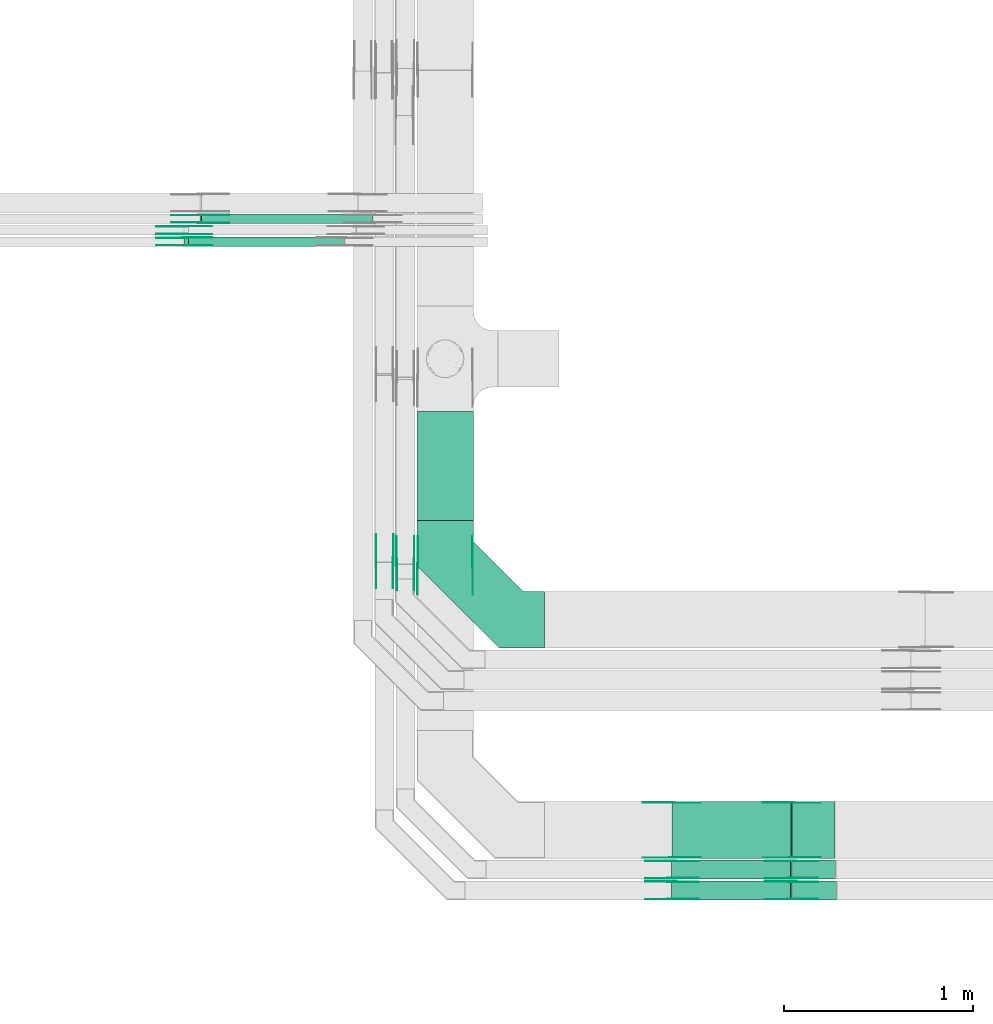
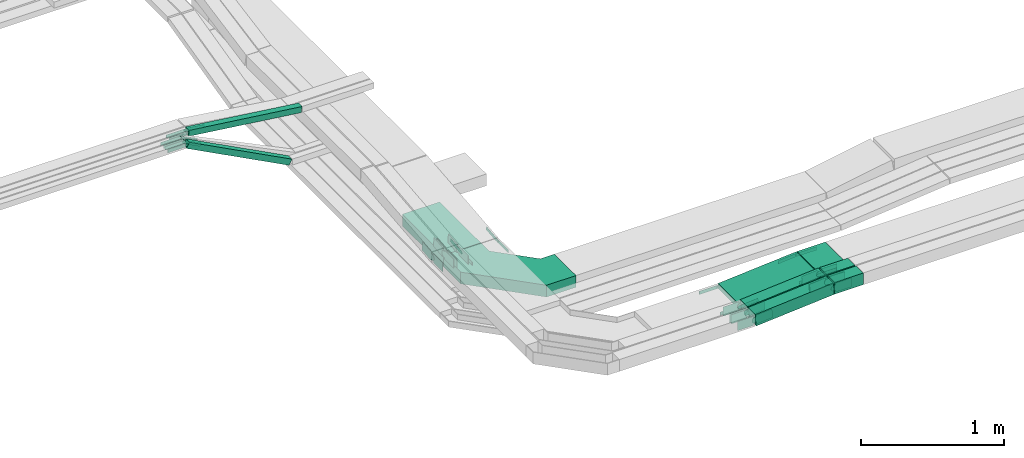
# One storey, part 6 of 33: 49 flow fittings, 9 flow segments.
"""IFC2X3 building model written with IfcOpenShell, lengths in millimetres."""

from ifc_helpers import new_model, entity, si_unit, converted_unit, derived_unit, direction, frame, frame_2d, origin, origin_2d_with_axis, place, context, subcontext, project, spatial, polyline, circle_curve, parameter, trimmed, segment, composite_curve, rectangle, outline, extrude, source, transform, mapped, material, type_object, type_shapes, element, save


model = new_model("IFC2X3")

# Units and contexts
model_context = context("Model", 3, precision=0.01, world=origin(), true_north=direction((6.12303176911189e-17, 1.0)))
body_context = subcontext(model_context, "Body", "Model", "MODEL_VIEW")
ifc_project = project(units=[si_unit("LENGTHUNIT", "METRE", prefix="MILLI"), si_unit("AREAUNIT", "SQUARE_METRE"), si_unit("VOLUMEUNIT", "CUBIC_METRE"), converted_unit("PLANEANGLEUNIT", "DEGREE", entity("IfcRatioMeasure", 0.0174532925199433), si_unit("PLANEANGLEUNIT", "RADIAN"), dimensions=[0, 0, 0, 0, 0, 0, 0]), si_unit("MASSUNIT", "GRAM", prefix="KILO"), derived_unit("MASSDENSITYUNIT", [(si_unit("MASSUNIT", "GRAM", prefix="KILO"), 1), (si_unit("LENGTHUNIT", "METRE"), -3)]), derived_unit("MOMENTOFINERTIAUNIT", [(si_unit("LENGTHUNIT", "METRE"), 4)]), si_unit("TIMEUNIT", "SECOND"), si_unit("FREQUENCYUNIT", "HERTZ"), si_unit("THERMODYNAMICTEMPERATUREUNIT", "DEGREE_CELSIUS"), derived_unit("THERMALTRANSMITTANCEUNIT", [(si_unit("MASSUNIT", "GRAM", prefix="KILO"), 1), (si_unit("THERMODYNAMICTEMPERATUREUNIT", "KELVIN"), -1), (si_unit("TIMEUNIT", "SECOND"), -3)]), derived_unit("VOLUMETRICFLOWRATEUNIT", [(si_unit("LENGTHUNIT", "METRE"), 3), (si_unit("TIMEUNIT", "SECOND"), -1)]), derived_unit("MASSFLOWRATEUNIT", [(si_unit("MASSUNIT", "GRAM", prefix="KILO"), 1), (si_unit("TIMEUNIT", "SECOND"), -1)]), derived_unit("ROTATIONALFREQUENCYUNIT", [(si_unit("TIMEUNIT", "SECOND"), -1)]), si_unit("ELECTRICCURRENTUNIT", "AMPERE"), si_unit("ELECTRICVOLTAGEUNIT", "VOLT"), si_unit("POWERUNIT", "WATT"), si_unit("FORCEUNIT", "NEWTON", prefix="KILO"), si_unit("ILLUMINANCEUNIT", "LUX"), si_unit("LUMINOUSFLUXUNIT", "LUMEN"), si_unit("LUMINOUSINTENSITYUNIT", "CANDELA"), derived_unit("USERDEFINED", [(si_unit("MASSUNIT", "GRAM", prefix="KILO"), -1), (si_unit("LENGTHUNIT", "METRE"), -2), (si_unit("TIMEUNIT", "SECOND"), 3), (si_unit("LUMINOUSFLUXUNIT", "LUMEN"), 1)]), derived_unit("LINEARVELOCITYUNIT", [(si_unit("LENGTHUNIT", "METRE"), 1), (si_unit("TIMEUNIT", "SECOND"), -1)]), si_unit("PRESSUREUNIT", "PASCAL"), derived_unit("USERDEFINED", [(si_unit("LENGTHUNIT", "METRE"), -2), (si_unit("MASSUNIT", "GRAM", prefix="KILO"), 1), (si_unit("TIMEUNIT", "SECOND"), -2)]), derived_unit("LINEARFORCEUNIT", [(si_unit("MASSUNIT", "GRAM", prefix="KILO"), 1), (si_unit("LENGTHUNIT", "METRE"), 1), (si_unit("TIMEUNIT", "SECOND"), -2), (si_unit("LENGTHUNIT", "METRE"), -1)]), derived_unit("PLANARFORCEUNIT", [(si_unit("MASSUNIT", "GRAM", prefix="KILO"), 1), (si_unit("LENGTHUNIT", "METRE"), 1), (si_unit("TIMEUNIT", "SECOND"), -2), (si_unit("LENGTHUNIT", "METRE"), -2)])], contexts=[model_context])

# Site, building, storey
site_placement = place(None, frame((0.0, -0.00077364408347762, 0.0)))
site = spatial("IfcSite", under=ifc_project, at=site_placement, CompositionType="ELEMENT")
building_placement = place(site_placement, origin())
building = spatial("IfcBuilding", under=site, at=building_placement, CompositionType="ELEMENT")
storey_placement = place(building_placement, frame((0.0, 0.0, 8100.0)))
storey = spatial("IfcBuildingStorey", under=building, at=storey_placement, CompositionType="ELEMENT", Elevation=8100.0)

# Flow segments
cable_carrier_segment_type = type_object("IfcCableCarrierSegmentType", PredefinedType="CABLETRAYSEGMENT")
flow_segment_1_placement = place(storey_placement, frame((18246.0523642072, 10520.9985534668, 2500.0)))
element("IfcFlowSegment", 1, at=flow_segment_1_placement, inside=storey, type_object=cable_carrier_segment_type, context=body_context, shape_type="SweptSolid", body=[
    extrude(rectangle(XDim=575.248008213486, YDim=300.000000000001, at=frame_2d((0.0, 2.17426077142591e-12), x_axis=(1.0, 0.0))), frame((150.0, 287.624004106748, 0.0), z_axis=(0.0, 0.0, 1.0), x_axis=(0.0, -1.0, 0.0)), (0.0, 0.0, 1.0), 99.9999999999989),
])
flow_segment_2_placement = place(storey_placement, frame((19596.2234512399, 8732.04668110773, 2740.2604319389)))
element("IfcFlowSegment", 2, at=flow_segment_2_placement, inside=storey, type_object=cable_carrier_segment_type, context=body_context, shape_type="SweptSolid", body=[
    extrude(rectangle(XDim=50.0000000000006, YDim=299.999999999999, at=frame_2d((0.0, 0.0), x_axis=(0.0, 1.0))), frame((1.96240772478632, 150.0, 24.922860107173), z_axis=(0.996914404286907, 0.0, 0.0784963089914518), x_axis=(0.0, 1.0, 0.0)), (0.0, 0.0, 1.0), 632.69257167876),
])
flow_segment_3_placement = place(storey_placement, frame((19595.2357822246, 8622.45182054443, 2739.93772748351)))
element("IfcFlowSegment", 3, at=flow_segment_3_placement, inside=storey, type_object=cable_carrier_segment_type, context=body_context, shape_type="SweptSolid", body=[
    extrude(rectangle(XDim=99.9999999999994, YDim=100.000000000001, at=frame_2d((0.0, 0.0), x_axis=(0.0, 1.0))), frame((3.93517206503428, 50.0, 49.8449036594347), z_axis=(0.996898073188744, 0.0, 0.0787034413006861), x_axis=(0.0, 1.0, 0.0)), (0.0, 0.0, 1.0), 630.726472303646),
])
flow_segment_4_placement = place(storey_placement, frame((19595.2938542408, 8512.45182054444, 2739.72291755436)))
element("IfcFlowSegment", 4, at=flow_segment_4_placement, inside=storey, type_object=cable_carrier_segment_type, context=body_context, shape_type="SweptSolid", body=[
    extrude(rectangle(XDim=99.9999999999991, YDim=99.9999999999989, at=frame_2d((0.0, 0.0), x_axis=(0.0, 1.0))), frame((3.92481544955964, 50.0, 49.8457202143459), z_axis=(0.996914404286927, 0.0, 0.0784963089911935), x_axis=(0.0, 1.0, 0.0)), (0.0, 0.0, 1.0), 630.673844252395),
])
flow_segment_5_placement = place(storey_placement, frame((20233.1995045216, 8732.04668110774, 2790.01530223377)))
element("IfcFlowSegment", 5, at=flow_segment_5_placement, inside=storey, type_object=cable_carrier_segment_type, context=body_context, shape_type="SweptSolid", body=[
    extrude(rectangle(XDim=226.881978270854, YDim=299.999999999999, at=frame_2d((0.0, 5.40012479177676e-13), x_axis=(1.0, 0.0))), frame((113.440989135427, 150.0, 0.0), z_axis=(0.0, 0.0, 1.0), x_axis=(-1.0, 0.0, 0.0)), (0.0, 0.0, 1.0), 50.0000000000016),
])
flow_segment_6_placement = place(storey_placement, frame((20234.1878431417, 8622.45182054443, 2789.6691825218)))
element("IfcFlowSegment", 6, at=flow_segment_6_placement, inside=storey, type_object=cable_carrier_segment_type, context=body_context, shape_type="SweptSolid", body=[
    extrude(rectangle(XDim=228.057615509405, YDim=99.9999999999989, at=origin_2d_with_axis()), frame((114.028807754702, 50.0, 0.0), z_axis=(0.0, 0.0, 1.0), x_axis=(-1.0, 0.0, 0.0)), (0.0, 0.0, 1.0), 99.9999999999989),
])
flow_segment_7_placement = place(storey_placement, frame((20234.1822245224, 8512.45182054444, 2789.31932519733)))
element("IfcFlowSegment", 7, at=flow_segment_7_placement, inside=storey, type_object=cable_carrier_segment_type, context=body_context, shape_type="SweptSolid", body=[
    extrude(rectangle(XDim=232.215307012604, YDim=99.9999999999989, at=origin_2d_with_axis()), frame((116.107653506302, 50.0, 0.0), z_axis=(0.0, 0.0, 1.0), x_axis=(-1.0, 0.0, 0.0)), (0.0, 0.0, 1.0), 99.9999999999989),
])
flow_segment_8_placement = place(storey_placement, frame((17015.1894000044, 11971.7526237039, 2626.62910408954)))
element("IfcFlowSegment", 8, at=flow_segment_8_placement, inside=storey, type_object=cable_carrier_segment_type, context=body_context, shape_type="SweptSolid", body=[
    extrude(rectangle(XDim=49.9999999999963, YDim=50.0000000000016, at=frame_2d((0.0, 0.0), x_axis=(0.0, 1.0))), frame((11.6001748667633, 25.0, 454.59600343892), z_axis=(0.885831535280106, 0.0, -0.464006994670651), x_axis=(0.0, 1.0, 0.0)), (0.0, 0.0, 1.0), 931.990724329228),
])
flow_segment_9_placement = place(storey_placement, frame((17099.2422570055, 12091.7526237039, 2944.30381418259)))
element("IfcFlowSegment", 9, at=flow_segment_9_placement, inside=storey, type_object=cable_carrier_segment_type, context=body_context, shape_type="SweptSolid", body=[
    extrude(rectangle(XDim=50.0000000000024, YDim=50.0000000000016, at=origin_2d_with_axis()), frame((3.15561380538458, 25.0, 140.338010413386), z_axis=(0.992001694765703, 0.0, -0.126224552215377), x_axis=(0.126224552215377, 0.0, 0.992001694765703)), (0.0, 0.0, 1.0), 915.336723453825),
])

# Flow fittings
ifc_material_1 = material()
cable_carrier_fitting_type_1 = type_object("IfcCableCarrierFittingType", Name="470_DKC_G5_Sheet horizontal bend:-", PredefinedType="NOTDEFINED", material=ifc_material_1)
shared_shape_1 = source(origin(), body_context, "Body", "SweptSolid", [
    extrude(outline(polyline([(-307.0, -369.0), (-68.8679656440352, -369.0), (369.0, 68.8679656440351), (369.0, 307.0), (69.0, 307.0), (69.0, 193.132034355964), (-193.132034355963, -69.0), (-307.0, -69.0), (-307.0, -369.0)])), frame((-219.0, 219.0, -50.0)), (0.0, 0.0, 1.0), 100.0),
])
type_shapes(cable_carrier_fitting_type_1, [shared_shape_1])
flow_fitting_placement = place(storey_placement, frame((18396.0523642072, 9994.99855346684, 2550.0), z_axis=(0.0, 0.0, 1.0), x_axis=(0.0, -1.0, 0.0)))
element("IfcFlowFitting", 10, at=flow_fitting_placement, inside=storey, type_object=cable_carrier_fitting_type_1, material=ifc_material_1, Name="470_DKC_G5_Sheet horizontal bend:-", ObjectType="470_DKC_G5_Sheet horizontal bend:-", context=body_context, shape_type="MappedRepresentation", body=[
    mapped(shared_shape_1, transform((0.0, 0.0, 0.0), scale=1.0)),
])
ifc_material_2 = material(Name="G")
cable_carrier_fitting_type_2 = type_object("IfcCableCarrierFittingType", PredefinedType="NOTDEFINED", material=ifc_material_2)
shared_shape_2 = source(origin(), body_context, "Body", "SweptSolid", [
    extrude(outline(composite_curve([segment(trimmed(circle_curve(frame_2d((-44.5901162790698, 0.0), x_axis=(1.0, 0.0)), 12.5), [parameter(90.0000000000007)], [parameter(270.0)], True, "PARAMETER"), True, "CONTINUOUS"), segment(polyline([(-44.5901162790697, -12.5), (-33.0901162790698, -12.5)]), True, "CONTINUOUS"), segment(polyline([(-33.0901162790698, -12.5), (-31.2296511627907, -14.5)]), True, "CONTINUOUS"), segment(polyline([(-31.2296511627907, -14.5), (108.90988372093, -14.5)]), True, "CONTINUOUS"), segment(polyline([(108.90988372093, -14.5), (108.90988372093, 14.5)]), True, "CONTINUOUS"), segment(polyline([(108.90988372093, 14.5), (-31.2296511627907, 14.5)]), True, "CONTINUOUS"), segment(polyline([(-31.2296511627907, 14.5), (-33.0901162790698, 12.5)]), True, "CONTINUOUS"), segment(polyline([(-33.0901162790698, 12.5), (-44.5901162790699, 12.5)]), True, "CONTINUOUS")], self_intersect=False)), frame((44.5901162790698, 0.0, 0.0), z_axis=(0.0, 0.0, -1.0), x_axis=(1.0, 0.0, 0.0)), (0.0, 0.0, -1.0), 2.0),
])
type_shapes(cable_carrier_fitting_type_2, [shared_shape_2])
for number, where, z_axis, x_axis in (
    (11, (20231.0595493208, 8736.58668109758, 2815.01530223381), (0.0, -1.0, 0.0), (-0.996914404286911, 0.0, -0.0784963089914033)),
    (12, (18250.5923641973, 10282.0466811094, 2765.0153134614), (-1.0, 0.0, 0.0), (0.0, -1.0, 0.0)),
    (13, (17099.5829619713, 12137.2126237141, 3085.0), (0.0, 1.0, 0.0), (0.992001694765699, 0.0, -0.126224552215409)),
    (14, (17019.5829619709, 12017.2126237141, 3085.0), (0.0, 1.0, 0.0), (0.885831535280083, 0.0, -0.464006994670695)),
    (15, (17019.582961971, 12077.2126237141, 3085.0), (0.0, 1.0, 0.0), (0.898384360919165, 0.0, -0.439210132005016)),
    (16, (19596.0525068004, 9027.50668111789, 2765.01531346139), (0.0, 1.0, 0.0), (-1.0, 0.0, 0.0)),
):
    element("IfcFlowFitting", number, at=place(storey_placement, frame(where, z_axis=z_axis, x_axis=x_axis)), inside=storey, type_object=cable_carrier_fitting_type_2, material=ifc_material_2, context=body_context, shape_type="MappedRepresentation", body=[
        mapped(shared_shape_2, transform((0.0, 0.0, 0.0), scale=1.0)),
    ])
cable_carrier_fitting_type_3 = type_object("IfcCableCarrierFittingType", PredefinedType="NOTDEFINED", material=ifc_material_2)
shared_shape_3 = source(origin(), body_context, "Body", "SweptSolid", [
    extrude(outline(composite_curve([segment(trimmed(circle_curve(frame_2d((-44.5901162790697, 0.0), x_axis=(1.0, 0.0)), 12.5), [parameter(90.0000000000007)], [parameter(270.0)], True, "PARAMETER"), True, "CONTINUOUS"), segment(polyline([(-44.5901162790697, -12.5), (-33.0901162790697, -12.5)]), True, "CONTINUOUS"), segment(polyline([(-33.0901162790697, -12.5), (-31.2296511627907, -14.5)]), True, "CONTINUOUS"), segment(polyline([(-31.2296511627907, -14.5), (108.90988372093, -14.5)]), True, "CONTINUOUS"), segment(polyline([(108.90988372093, -14.5), (108.90988372093, 14.5)]), True, "CONTINUOUS"), segment(polyline([(108.90988372093, 14.5), (-31.2296511627907, 14.5)]), True, "CONTINUOUS"), segment(polyline([(-31.2296511627907, 14.5), (-33.0901162790698, 12.5)]), True, "CONTINUOUS"), segment(polyline([(-33.0901162790698, 12.5), (-44.5901162790699, 12.5)]), True, "CONTINUOUS")], self_intersect=False)), frame((44.5901162790697, 0.0, 0.0)), (0.0, 0.0, 1.0), 2.0),
])
type_shapes(cable_carrier_fitting_type_3, [shared_shape_3])
for number, where, z_axis, x_axis in (
    (17, (20231.0595493208, 9027.5066811179, 2815.01530223381), (0.0, 1.0, 0.0), (-0.996914404286911, 0.0, -0.0784963089914033)),
    (18, (18541.5123642176, 10282.0466811094, 2765.0153134614), (1.0, 0.0, 0.0), (0.0, -1.0, 0.0)),
    (19, (17099.5829619713, 12096.2926236938, 3085.0), (0.0, -1.0, 0.0), (0.992001694765699, 0.0, -0.126224552215409)),
    (20, (17019.5829619709, 11976.2926236938, 3085.0), (0.0, -1.0, 0.0), (0.885831535280083, 0.0, -0.464006994670695)),
    (21, (17019.582961971, 12036.2926236938, 3085.0), (0.0, -1.0, 0.0), (0.898384360919165, 0.0, -0.439210132005016)),
    (22, (19596.0525068004, 8736.58668109757, 2765.01531346139), (0.0, -1.0, 0.0), (-1.0, 0.0, 0.0)),
):
    element("IfcFlowFitting", number, at=place(storey_placement, frame(where, z_axis=z_axis, x_axis=x_axis)), inside=storey, type_object=cable_carrier_fitting_type_3, material=ifc_material_2, context=body_context, shape_type="MappedRepresentation", body=[
        mapped(shared_shape_3, transform((0.0, 0.0, 0.0), scale=1.0)),
    ])
cable_carrier_fitting_type_4 = type_object("IfcCableCarrierFittingType", PredefinedType="NOTDEFINED", material=ifc_material_2)
shared_shape_4 = source(origin(), body_context, "Body", "SweptSolid", [
    extrude(outline(composite_curve([segment(trimmed(circle_curve(frame_2d((-44.5901162790698, 0.0), x_axis=(1.0, 0.0)), 12.5), [parameter(90.0000000000007)], [parameter(270.0)], True, "PARAMETER"), True, "CONTINUOUS"), segment(polyline([(-44.5901162790697, -12.5), (-33.0901162790698, -12.5)]), True, "CONTINUOUS"), segment(polyline([(-33.0901162790698, -12.5), (-31.2296511627907, -14.5)]), True, "CONTINUOUS"), segment(polyline([(-31.2296511627907, -14.5), (108.90988372093, -14.5)]), True, "CONTINUOUS"), segment(polyline([(108.90988372093, -14.5), (108.90988372093, 14.5)]), True, "CONTINUOUS"), segment(polyline([(108.90988372093, 14.5), (-31.2296511627907, 14.5)]), True, "CONTINUOUS"), segment(polyline([(-31.2296511627907, 14.5), (-33.0901162790698, 12.5)]), True, "CONTINUOUS"), segment(polyline([(-33.0901162790698, 12.5), (-44.5901162790699, 12.5)]), True, "CONTINUOUS")], self_intersect=False)), frame((44.5901162790698, 0.0, 0.0), z_axis=(0.0, 0.0, -1.0), x_axis=(1.0, 0.0, 0.0)), (0.0, 0.0, -1.0), 2.0),
])
type_shapes(cable_carrier_fitting_type_4, [shared_shape_4])
for number, where, z_axis, x_axis in (
    (23, (20231.0595493207, 9025.5066811179, 2815.01530223381), (0.0, 1.0, 0.0), (1.0, 0.0, 0.0)),
    (24, (18539.5123642176, 10282.0466811094, 2765.0153134614), (1.0, 0.0, 0.0), (0.0, 0.99497485470274, 0.100125114278398)),
    (25, (17099.5829619713, 12098.2926236938, 3085.0), (0.0, -1.0, 0.0), (-1.0, 0.0, 0.0)),
    (26, (17019.5829619709, 11978.2926236938, 3085.0), (0.0, -1.0, 0.0), (-1.0, 0.0, 0.0)),
    (27, (17019.582961971, 12038.2926236938, 3085.0), (0.0, -1.0, 0.0), (-1.0, 0.0, 0.0)),
    (28, (19596.0525068004, 8738.58668109757, 2765.01531346139), (0.0, -1.0, 0.0), (0.996914404286914, 0.0, 0.0784963089913655)),
):
    element("IfcFlowFitting", number, at=place(storey_placement, frame(where, z_axis=z_axis, x_axis=x_axis)), inside=storey, type_object=cable_carrier_fitting_type_4, material=ifc_material_2, context=body_context, shape_type="MappedRepresentation", body=[
        mapped(shared_shape_4, transform((0.0, 0.0, 0.0), scale=1.0)),
    ])
cable_carrier_fitting_type_5 = type_object("IfcCableCarrierFittingType", PredefinedType="NOTDEFINED", material=ifc_material_2)
shared_shape_5 = source(origin(), body_context, "Body", "SweptSolid", [
    extrude(outline(composite_curve([segment(trimmed(circle_curve(frame_2d((-44.5901162790697, 0.0), x_axis=(1.0, 0.0)), 12.5), [parameter(90.0000000000007)], [parameter(270.0)], True, "PARAMETER"), True, "CONTINUOUS"), segment(polyline([(-44.5901162790697, -12.5), (-33.0901162790697, -12.5)]), True, "CONTINUOUS"), segment(polyline([(-33.0901162790697, -12.5), (-31.2296511627907, -14.5)]), True, "CONTINUOUS"), segment(polyline([(-31.2296511627907, -14.5), (108.90988372093, -14.5)]), True, "CONTINUOUS"), segment(polyline([(108.90988372093, -14.5), (108.90988372093, 14.5)]), True, "CONTINUOUS"), segment(polyline([(108.90988372093, 14.5), (-31.2296511627907, 14.5)]), True, "CONTINUOUS"), segment(polyline([(-31.2296511627907, 14.5), (-33.0901162790698, 12.5)]), True, "CONTINUOUS"), segment(polyline([(-33.0901162790698, 12.5), (-44.5901162790699, 12.5)]), True, "CONTINUOUS")], self_intersect=False)), frame((44.5901162790697, 0.0, 0.0)), (0.0, 0.0, 1.0), 2.0),
])
type_shapes(cable_carrier_fitting_type_5, [shared_shape_5])
for number, where, z_axis, x_axis in (
    (29, (20231.0595493207, 8738.58668109759, 2815.01530223381), (0.0, -1.0, 0.0), (1.0, 0.0, 0.0)),
    (30, (18252.5923641973, 10282.0466811094, 2765.0153134614), (-1.0, 0.0, 0.0), (0.0, 0.99497485470274, 0.100125114278398)),
    (31, (17099.5829619713, 12135.2126237141, 3085.0), (0.0, 1.0, 0.0), (-1.0, 0.0, 0.0)),
    (32, (17019.5829619709, 12015.2126237141, 3085.0), (0.0, 1.0, 0.0), (-1.0, 0.0, 0.0)),
    (33, (17019.582961971, 12075.2126237141, 3085.0), (0.0, 1.0, 0.0), (-1.0, 0.0, 0.0)),
    (34, (19596.0525068004, 9025.50668111788, 2765.01531346139), (0.0, 1.0, 0.0), (0.996914404286914, 0.0, 0.0784963089913655)),
):
    element("IfcFlowFitting", number, at=place(storey_placement, frame(where, z_axis=z_axis, x_axis=x_axis)), inside=storey, type_object=cable_carrier_fitting_type_5, material=ifc_material_2, context=body_context, shape_type="MappedRepresentation", body=[
        mapped(shared_shape_5, transform((0.0, 0.0, 0.0), scale=1.0)),
    ])
cable_carrier_fitting_type_6 = type_object("IfcCableCarrierFittingType", PredefinedType="NOTDEFINED", material=ifc_material_2)
shared_shape_6 = source(origin(), body_context, "Body", "SweptSolid", [
    extrude(outline(composite_curve([segment(trimmed(circle_curve(frame_2d((-41.4651162790697, 0.0), x_axis=(1.0, 0.0)), 25.0), [parameter(90.0000000000007)], [parameter(270.0)], True, "PARAMETER"), True, "CONTINUOUS"), segment(polyline([(-41.4651162790697, -25.0), (-29.9651162790697, -25.0)]), True, "CONTINUOUS"), segment(polyline([(-29.9651162790697, -25.0), (-28.1046511627907, -38.5)]), True, "CONTINUOUS"), segment(polyline([(-28.1046511627907, -38.5), (99.5348837209303, -38.5)]), True, "CONTINUOUS"), segment(polyline([(99.5348837209303, -38.5), (99.5348837209303, 38.5)]), True, "CONTINUOUS"), segment(polyline([(99.5348837209303, 38.5), (-28.1046511627907, 38.5)]), True, "CONTINUOUS"), segment(polyline([(-28.1046511627907, 38.5), (-29.9651162790697, 25.0)]), True, "CONTINUOUS"), segment(polyline([(-29.9651162790697, 25.0), (-41.46511627907, 25.0)]), True, "CONTINUOUS")], self_intersect=False)), frame((41.4651162790697, 0.0, 0.0), z_axis=(0.0, 0.0, -1.0), x_axis=(1.0, 0.0, 0.0)), (0.0, 0.0, -1.0), 2.0),
])
type_shapes(cable_carrier_fitting_type_6, [shared_shape_6])
for number, where, z_axis, x_axis in (
    (35, (18231.5123642175, 10292.4518205444, 2789.53642365382), (1.0, 0.0, 0.0), (0.0, 0.994821450765371, 0.101637990422292)),
    (36, (18121.5123642176, 10302.4518205449, 2789.32351929117), (1.0, 0.0, 0.0), (0.0, 0.994903033239732, 0.100836275468608)),
    (37, (20231.0595493208, 8626.99182053427, 2839.66918252182), (0.0, -1.0, 0.0), (-0.99689807318874, 0.0, -0.0787034413007328)),
    (38, (20231.0595493209, 8516.99182053428, 2839.31932519734), (0.0, -1.0, 0.0), (-0.996914404286923, 0.0, -0.0784963089912431)),
    (39, (19596.105629802, 8607.91182055459, 2789.32351929118), (0.0, 1.0, 0.0), (-1.0, 0.0, 0.0)),
    (40, (19596.0523642071, 8717.91182055459, 2789.53642365381), (0.0, 1.0, 0.0), (-1.0, 0.0, 0.0)),
):
    element("IfcFlowFitting", number, at=place(storey_placement, frame(where, z_axis=z_axis, x_axis=x_axis)), inside=storey, type_object=cable_carrier_fitting_type_6, material=ifc_material_2, context=body_context, shape_type="MappedRepresentation", body=[
        mapped(shared_shape_6, transform((0.0, 0.0, 0.0), scale=1.0)),
    ])
cable_carrier_fitting_type_7 = type_object("IfcCableCarrierFittingType", PredefinedType="NOTDEFINED", material=ifc_material_2)
shared_shape_7 = source(origin(), body_context, "Body", "SweptSolid", [
    extrude(outline(composite_curve([segment(trimmed(circle_curve(frame_2d((-41.4651162790697, 0.0), x_axis=(1.0, 0.0)), 25.0), [parameter(90.0000000000007)], [parameter(270.0)], True, "PARAMETER"), True, "CONTINUOUS"), segment(polyline([(-41.4651162790697, -25.0), (-29.9651162790697, -25.0)]), True, "CONTINUOUS"), segment(polyline([(-29.9651162790697, -25.0), (-28.1046511627907, -38.5)]), True, "CONTINUOUS"), segment(polyline([(-28.1046511627907, -38.5), (99.5348837209303, -38.5)]), True, "CONTINUOUS"), segment(polyline([(99.5348837209303, -38.5), (99.5348837209303, 38.5)]), True, "CONTINUOUS"), segment(polyline([(99.5348837209303, 38.5), (-28.1046511627907, 38.5)]), True, "CONTINUOUS"), segment(polyline([(-28.1046511627907, 38.5), (-29.9651162790697, 25.0)]), True, "CONTINUOUS"), segment(polyline([(-29.9651162790697, 25.0), (-41.46511627907, 25.0)]), True, "CONTINUOUS")], self_intersect=False)), frame((41.4651162790697, 0.0, 0.0)), (0.0, 0.0, 1.0), 2.0),
])
type_shapes(cable_carrier_fitting_type_7, [shared_shape_7])
for number, where, z_axis, x_axis in (
    (41, (18140.5923641972, 10292.4518205444, 2789.53642365382), (-1.0, 0.0, 0.0), (0.0, 0.994821450765371, 0.101637990422292)),
    (42, (18030.5923641973, 10302.4518205449, 2789.32351929117), (-1.0, 0.0, 0.0), (0.0, 0.994903033239732, 0.100836275468608)),
    (43, (20231.0595493208, 8717.91182055459, 2839.66918252183), (0.0, 1.0, 0.0), (-0.99689807318874, 0.0, -0.0787034413007328)),
    (44, (20231.0595493209, 8607.91182055459, 2839.31932519735), (0.0, 1.0, 0.0), (-0.996914404286923, 0.0, -0.0784963089912431)),
    (45, (19596.105629802, 8516.99182053428, 2789.32351929118), (0.0, -1.0, 0.0), (-1.0, 0.0, 0.0)),
    (46, (19596.0523642071, 8626.99182053427, 2789.53642365381), (0.0, -1.0, 0.0), (-1.0, 0.0, 0.0)),
):
    element("IfcFlowFitting", number, at=place(storey_placement, frame(where, z_axis=z_axis, x_axis=x_axis)), inside=storey, type_object=cable_carrier_fitting_type_7, material=ifc_material_2, context=body_context, shape_type="MappedRepresentation", body=[
        mapped(shared_shape_7, transform((0.0, 0.0, 0.0), scale=1.0)),
    ])
cable_carrier_fitting_type_8 = type_object("IfcCableCarrierFittingType", PredefinedType="NOTDEFINED", material=ifc_material_2)
shared_shape_8 = source(origin(), body_context, "Body", "SweptSolid", [
    extrude(outline(composite_curve([segment(trimmed(circle_curve(frame_2d((-41.4651162790697, 0.0), x_axis=(1.0, 0.0)), 25.0), [parameter(90.0000000000007)], [parameter(270.0)], True, "PARAMETER"), True, "CONTINUOUS"), segment(polyline([(-41.4651162790697, -25.0), (-29.9651162790697, -25.0)]), True, "CONTINUOUS"), segment(polyline([(-29.9651162790697, -25.0), (-28.1046511627907, -38.5)]), True, "CONTINUOUS"), segment(polyline([(-28.1046511627907, -38.5), (99.5348837209303, -38.5)]), True, "CONTINUOUS"), segment(polyline([(99.5348837209303, -38.5), (99.5348837209303, 38.5)]), True, "CONTINUOUS"), segment(polyline([(99.5348837209303, 38.5), (-28.1046511627907, 38.5)]), True, "CONTINUOUS"), segment(polyline([(-28.1046511627907, 38.5), (-29.9651162790697, 25.0)]), True, "CONTINUOUS"), segment(polyline([(-29.9651162790697, 25.0), (-41.46511627907, 25.0)]), True, "CONTINUOUS")], self_intersect=False)), frame((41.4651162790697, 0.0, 0.0), z_axis=(0.0, 0.0, -1.0), x_axis=(1.0, 0.0, 0.0)), (0.0, 0.0, -1.0), 2.0),
])
type_shapes(cable_carrier_fitting_type_8, [shared_shape_8])
for number, where, z_axis, x_axis in (
    (47, (18142.5923641972, 10292.4518205445, 2789.53642365382), (-1.0, 0.0, 0.0), (0.0, -1.0, 0.0)),
    (48, (18032.5923641973, 10302.4518205449, 2789.32351929118), (-1.0, 0.0, 0.0), (0.0, -1.0, 0.0)),
    (49, (20231.0595493208, 8715.91182055459, 2839.66918252182), (0.0, 1.0, 0.0), (1.0, 0.0, 0.0)),
    (50, (20231.0595493209, 8605.91182055459, 2839.31932519734), (0.0, 1.0, 0.0), (1.0, 0.0, 0.0)),
    (51, (19596.105629802, 8518.99182053428, 2789.32351929119), (0.0, -1.0, 0.0), (0.996914404286925, 0.0, 0.0784963089912197)),
    (52, (19596.0523642071, 8628.99182053427, 2789.53642365381), (0.0, -1.0, 0.0), (0.996898073188743, 0.0, 0.0787034413006984)),
):
    element("IfcFlowFitting", number, at=place(storey_placement, frame(where, z_axis=z_axis, x_axis=x_axis)), inside=storey, type_object=cable_carrier_fitting_type_8, material=ifc_material_2, context=body_context, shape_type="MappedRepresentation", body=[
        mapped(shared_shape_8, transform((0.0, 0.0, 0.0), scale=1.0)),
    ])
cable_carrier_fitting_type_9 = type_object("IfcCableCarrierFittingType", PredefinedType="NOTDEFINED", material=ifc_material_2)
shared_shape_9 = source(origin(), body_context, "Body", "SweptSolid", [
    extrude(outline(composite_curve([segment(trimmed(circle_curve(frame_2d((-41.4651162790697, 0.0), x_axis=(1.0, 0.0)), 25.0), [parameter(90.0000000000007)], [parameter(270.0)], True, "PARAMETER"), True, "CONTINUOUS"), segment(polyline([(-41.4651162790697, -25.0), (-29.9651162790697, -25.0)]), True, "CONTINUOUS"), segment(polyline([(-29.9651162790697, -25.0), (-28.1046511627907, -38.5)]), True, "CONTINUOUS"), segment(polyline([(-28.1046511627907, -38.5), (99.5348837209303, -38.5)]), True, "CONTINUOUS"), segment(polyline([(99.5348837209303, -38.5), (99.5348837209303, 38.5)]), True, "CONTINUOUS"), segment(polyline([(99.5348837209303, 38.5), (-28.1046511627907, 38.5)]), True, "CONTINUOUS"), segment(polyline([(-28.1046511627907, 38.5), (-29.9651162790697, 25.0)]), True, "CONTINUOUS"), segment(polyline([(-29.9651162790697, 25.0), (-41.46511627907, 25.0)]), True, "CONTINUOUS")], self_intersect=False)), frame((41.4651162790697, 0.0, 0.0)), (0.0, 0.0, 1.0), 2.0),
])
type_shapes(cable_carrier_fitting_type_9, [shared_shape_9])
for number, where, z_axis, x_axis in (
    (53, (18229.5123642175, 10292.4518205445, 2789.53642365382), (1.0, 0.0, 0.0), (0.0, -1.0, 0.0)),
    (54, (18119.5123642176, 10302.4518205449, 2789.32351929118), (1.0, 0.0, 0.0), (0.0, -1.0, 0.0)),
    (55, (20231.0595493208, 8628.99182053427, 2839.66918252182), (0.0, -1.0, 0.0), (1.0, 0.0, 0.0)),
    (56, (20231.0595493209, 8518.99182053428, 2839.31932519734), (0.0, -1.0, 0.0), (1.0, 0.0, 0.0)),
    (57, (19596.105629802, 8605.91182055459, 2789.32351929119), (0.0, 1.0, 0.0), (0.996914404286925, 0.0, 0.0784963089912197)),
    (58, (19596.0523642071, 8715.91182055459, 2789.53642365381), (0.0, 1.0, 0.0), (0.996898073188743, 0.0, 0.0787034413006984)),
):
    element("IfcFlowFitting", number, at=place(storey_placement, frame(where, z_axis=z_axis, x_axis=x_axis)), inside=storey, type_object=cable_carrier_fitting_type_9, material=ifc_material_2, context=body_context, shape_type="MappedRepresentation", body=[
        mapped(shared_shape_9, transform((0.0, 0.0, 0.0), scale=1.0)),
    ])

save(model, "model.ifc")
